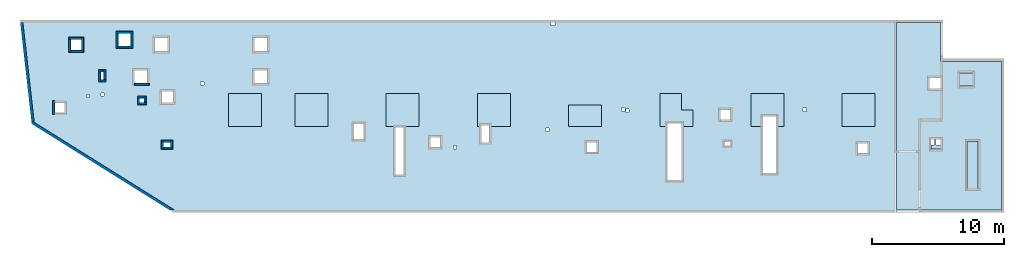
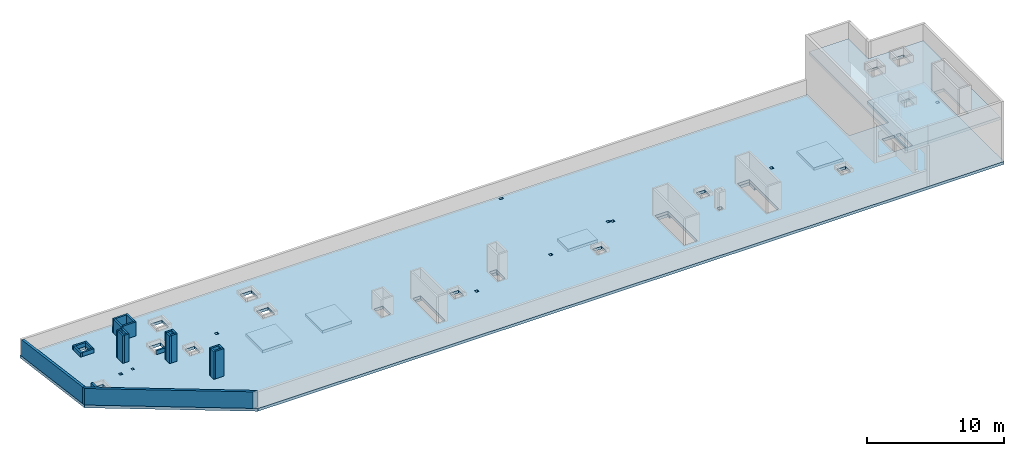
# One storey, part 1 of 3: 24 walls, 10 slabs.
"""IFC4 building model written with IfcOpenShell, lengths in millimetres."""

from ifc_helpers import new_model, entity, si_unit, converted_unit, derived_unit, direction, frame, origin, place, context, subcontext, project, spatial, indexed_curve, outline, extrude, material, type_object, element, save


model = new_model("IFC4")

# Units and contexts
model_context = context("Model", 3, precision=0.01, world=origin(), true_north=direction((6.12303176911189e-17, 1.0)))
plan_context = context("Plan", 3, precision=0.01, world=origin(), true_north=direction((6.12303176911189e-17, 1.0)))
body_context = subcontext(model_context, "Body", "Model", "MODEL_VIEW")
ifc_project = project(units=[si_unit("LENGTHUNIT", "METRE", prefix="MILLI"), si_unit("AREAUNIT", "SQUARE_METRE"), si_unit("VOLUMEUNIT", "CUBIC_METRE"), converted_unit("PLANEANGLEUNIT", "DEGREE", entity("IfcRatioMeasure", 0.0174532925199433), si_unit("PLANEANGLEUNIT", "RADIAN"), dimensions=[0, 0, 0, 0, 0, 0, 0]), si_unit("MASSUNIT", "GRAM", prefix="KILO"), derived_unit("MASSDENSITYUNIT", [(si_unit("MASSUNIT", "GRAM", prefix="KILO"), 1), (si_unit("LENGTHUNIT", "METRE"), -3)]), derived_unit("MOMENTOFINERTIAUNIT", [(si_unit("LENGTHUNIT", "METRE"), 4)]), si_unit("TIMEUNIT", "SECOND"), si_unit("FREQUENCYUNIT", "HERTZ"), si_unit("THERMODYNAMICTEMPERATUREUNIT", "DEGREE_CELSIUS"), derived_unit("THERMALTRANSMITTANCEUNIT", [(si_unit("MASSUNIT", "GRAM", prefix="KILO"), 1), (si_unit("THERMODYNAMICTEMPERATUREUNIT", "KELVIN"), -1), (si_unit("TIMEUNIT", "SECOND"), -3)]), derived_unit("VOLUMETRICFLOWRATEUNIT", [(si_unit("LENGTHUNIT", "METRE"), 3), (si_unit("TIMEUNIT", "SECOND"), -1)]), derived_unit("MASSFLOWRATEUNIT", [(si_unit("MASSUNIT", "GRAM", prefix="KILO"), 1), (si_unit("TIMEUNIT", "SECOND"), -1)]), derived_unit("ROTATIONALFREQUENCYUNIT", [(si_unit("TIMEUNIT", "SECOND"), -1)]), si_unit("ELECTRICCURRENTUNIT", "AMPERE"), si_unit("ELECTRICVOLTAGEUNIT", "VOLT"), si_unit("POWERUNIT", "WATT"), si_unit("FORCEUNIT", "NEWTON", prefix="KILO"), si_unit("ILLUMINANCEUNIT", "LUX"), si_unit("LUMINOUSFLUXUNIT", "LUMEN"), si_unit("LUMINOUSINTENSITYUNIT", "CANDELA"), derived_unit("USERDEFINED", [(si_unit("MASSUNIT", "GRAM", prefix="KILO"), -1), (si_unit("LENGTHUNIT", "METRE"), -2), (si_unit("TIMEUNIT", "SECOND"), 3), (si_unit("LUMINOUSFLUXUNIT", "LUMEN"), 1)]), derived_unit("LINEARVELOCITYUNIT", [(si_unit("LENGTHUNIT", "METRE"), 1), (si_unit("TIMEUNIT", "SECOND"), -1)]), si_unit("PRESSUREUNIT", "PASCAL"), derived_unit("USERDEFINED", [(si_unit("LENGTHUNIT", "METRE"), -2), (si_unit("MASSUNIT", "GRAM", prefix="KILO"), 1), (si_unit("TIMEUNIT", "SECOND"), -2)]), derived_unit("LINEARFORCEUNIT", [(si_unit("MASSUNIT", "GRAM", prefix="KILO"), 1), (si_unit("LENGTHUNIT", "METRE"), 1), (si_unit("TIMEUNIT", "SECOND"), -2), (si_unit("LENGTHUNIT", "METRE"), -1)]), derived_unit("PLANARFORCEUNIT", [(si_unit("MASSUNIT", "GRAM", prefix="KILO"), 1), (si_unit("LENGTHUNIT", "METRE"), 1), (si_unit("TIMEUNIT", "SECOND"), -2), (si_unit("LENGTHUNIT", "METRE"), -2)])], contexts=[model_context, plan_context])

# Site, building, storey
site_placement = place(None, origin())
site = spatial("IfcSite", under=ifc_project, at=site_placement, CompositionType="ELEMENT")
building_placement = place(site_placement, origin())
building = spatial("IfcBuilding", under=site, at=building_placement, CompositionType="ELEMENT")
storey_placement = place(building_placement, frame((0.0, 0.0, 32250.0)))
storey = spatial("IfcBuildingStorey", under=building, at=storey_placement, CompositionType="ELEMENT", Elevation=32250.0)

# Slabs
ifc_material = material()
slab_type_1 = type_object("IfcSlabType", Name=":ADSK_ 25_250", PredefinedType="FLOOR", material=ifc_material)
placement = place(storey_placement, origin())
element("IfcSlab", 1, at=placement, inside=storey, type_object=slab_type_1, material=ifc_material, Name=":ADSK_ 25_250", ObjectType=":ADSK_ 25_250", PredefinedType="FLOOR", context=body_context, shape_type="SweptSolid", body=[
    extrude(outline(indexed_curve([(-28210.243401448, -11264.7051743326), (34622.2927188456, -11264.7051743326), (34622.2927188456, 375.294825667434), (29822.2935367167, 375.294825667426), (29822.2935367167, -2764.70517433255), (26482.2935367167, -2764.70517433256), (26482.2935367167, 3305.29546503463), (-39839.7064632833, 3305.29546503461), (-38947.8468191642, -4555.23683038923), (-28210.243401448, -11264.7051743326)], self_intersect=False), holes=[indexed_curve([(-36462.7064632833, -2944.70517433183), (-36462.7064632833, -3694.70517433183), (-37212.7064632833, -3694.70517433183), (-37212.7064632833, -2944.70517433183), (-36462.7064632833, -2944.70517433183)], self_intersect=False), indexed_curve([(-35152.7064632833, 1855.29482566817), (-35152.7064632833, 1005.29482566817), (-36002.7064632834, 1005.29482566817), (-36002.7064632834, 1855.29482566817), (-35152.7064632833, 1855.29482566817)], self_intersect=False), indexed_curve([(-33497.7064632833, -2234.70517433184), (-33497.7064632833, -2434.70517433184), (-33697.7064632833, -2434.70517433184), (-33697.7064632833, -2234.70517433184), (-33497.7064632833, -2234.70517433184)], self_intersect=False), indexed_curve([(-34567.7064632833, -2324.70517433183), (-34567.7064632833, -2574.70517433183), (-34817.7064632833, -2574.70517433183), (-34817.7064632833, -2324.70517433183), (-34567.7064632833, -2324.70517433183)], self_intersect=False), indexed_curve([(-25922.7064632833, -1369.70517433186), (-25922.7064632833, -1619.70517433186), (-26172.7064632833, -1619.70517433186), (-26172.7064632833, -1369.70517433186), (-25922.7064632833, -1369.70517433186)], self_intersect=False), indexed_curve([(-28247.7064632833, -2094.70517433186), (-28247.7064632833, -2944.70517433186), (-29097.7064632833, -2944.70517433186), (-29097.7064632833, -2094.70517433186), (-28247.7064632833, -2094.70517433186)], self_intersect=False), indexed_curve([(-30447.7064632833, -2604.70517433184), (-30447.7064632833, -2954.70517433184), (-30797.7064632833, -2954.70517433184), (-30797.7064632833, -2604.70517433184), (-30447.7064632833, -2604.70517433184)], self_intersect=False), indexed_curve([(-30197.7064632833, -494.705174331843), (-30197.7064632833, -1494.70517433184), (-31197.7064632833, -1494.70517433185), (-31197.7064632833, -494.705174331847), (-30197.7064632833, -494.705174331843)], self_intersect=False), indexed_curve([(-28647.7064632833, 1955.29546503462), (-28647.7064632833, 955.295465034616), (-29647.7064632833, 955.295465034613), (-29647.7064632833, 1955.29546503462), (-28647.7064632833, 1955.29546503462)], self_intersect=False), indexed_curve([(-31447.7064632833, 2285.29546503462), (-31447.7064632833, 1325.29546503462), (-32407.7064632833, 1325.29546503462), (-32407.7064632833, 2285.29546503461), (-31447.7064632833, 2285.29546503462)], self_intersect=False), indexed_curve([(-33497.7064632833, -624.705174331836), (-33497.7064632833, -1224.70517433184), (-33747.7064632833, -1224.70517433184), (-33747.7064632833, -624.705174331837), (-33497.7064632833, -624.705174331836)], self_intersect=False), indexed_curve([(-28447.7064632833, -5959.70517433185), (-28447.7064632833, -6309.70517433185), (-28997.7064632833, -6309.70517433185), (-28997.7064632833, -5959.70517433185), (-28447.7064632833, -5959.70517433185)], self_intersect=False), indexed_curve([(-21127.7064632833, -494.704534965379), (-21127.7064632833, -1494.70453496538), (-22127.7064632833, -1494.70453496538), (-22127.7064632833, -494.704534965383), (-21127.7064632833, -494.704534965379)], self_intersect=False), indexed_curve([(-21127.7064632833, 1955.29546503462), (-21127.7064632833, 955.29546503462), (-22127.7064632833, 955.295465034621), (-22127.7064632833, 1955.29546503462), (-21127.7064632833, 1955.29546503462)], self_intersect=False), indexed_curve([(-13822.7064632833, -4554.7051743319), (-13822.7064632833, -5704.7051743319), (-14572.7064632833, -5704.7051743319), (-14572.7064632833, -4554.7051743319), (-13822.7064632833, -4554.7051743319)], self_intersect=False), indexed_curve([(-10782.7064632833, -4794.70517433239), (-10782.7064632833, -8394.7051743324), (-11432.7064632833, -8394.7051743324), (-11432.7064632833, -4794.7051743324), (-10782.7064632833, -4794.70517433239)], self_intersect=False), indexed_curve([(-8037.70646328332, -5559.70517433193), (-8037.70646328333, -6309.70517433194), (-8787.70646328334, -6309.70517433194), (-8787.70646328332, -5559.70517433194), (-8037.70646328332, -5559.70517433193)], self_intersect=False), indexed_curve([(-6797.70646328332, -6189.70517433193), (-6797.70646328332, -6439.70517433193), (-7047.70646328332, -6439.70517433192), (-7047.70646328333, -6189.70517433192), (-6797.70646328332, -6189.70517433193)], self_intersect=False), indexed_curve([(-4327.70646328331, -4664.70517433239), (-4327.7064632833, -5964.70517433239), (-4927.7064632833, -5964.7051743324), (-4927.70646328331, -4664.70517433239), (-4327.70646328331, -4664.70517433239)], self_intersect=False), indexed_curve([(197.293536716675, -4869.70517433194), (197.293536716676, -5119.70517433194), (-52.7064632833368, -5119.70517433194), (-52.706463283329, -4869.70517433194), (197.293536716675, -4869.70517433194)], self_intersect=False), indexed_curve([(652.293536716691, 3105.29546503454), (652.293536716692, 2905.29546503454), (352.293536716691, 2905.29546503454), (352.293536716682, 3105.29546503453), (652.293536716691, 3105.29546503454)], self_intersect=False), indexed_curve([(10222.2935367167, -4504.70517433248), (10222.2935367167, -8804.70517433249), (9122.29353671668, -8804.7051743325), (9122.29353671668, -4504.70517433249), (10222.2935367167, -4504.70517433248)], self_intersect=False), indexed_curve([(5937.29353671669, -3329.70517433197), (5937.29353671669, -3579.70517433197), (5687.29353671668, -3579.70517433197), (5687.29353671669, -3329.70517433197), (5937.29353671669, -3329.70517433197)], self_intersect=False), indexed_curve([(6257.2935367167, -3439.70517433198), (6257.29353671668, -3689.70517433198), (6007.29353671668, -3689.70517433198), (6007.29353671669, -3439.70517433198), (6257.2935367167, -3439.70517433198)], self_intersect=False), indexed_curve([(3812.2935367167, -5934.70517433198), (3812.2935367167, -6684.70517433198), (3062.29353671669, -6684.70517433198), (3062.29353671669, -5934.70517433198), (3812.2935367167, -5934.70517433198)], self_intersect=False), indexed_curve([(13912.2935367167, -3494.705174332), (13912.2935367167, -4244.705174332), (13162.2935367167, -4244.705174332), (13162.2935367167, -3494.705174332), (13912.2935367167, -3494.705174332)], self_intersect=False), indexed_curve([(13902.2935367167, -5919.70517433199), (13902.2935367167, -6219.705174332), (13502.2935367167, -6219.705174332), (13502.2935367167, -5919.70517433199), (13902.2935367167, -5919.70517433199)], self_intersect=False), indexed_curve([(17372.2935367167, -3984.70517433251), (17372.2935367167, -8284.70517433251), (16372.2935367167, -8284.70517433252), (16372.2935367167, -3984.70517433252), (17372.2935367167, -3984.70517433251)], self_intersect=False), indexed_curve([(19662.2935367167, -3369.70517433203), (19662.2935367167, -3619.70517433203), (19412.2935367167, -3619.70517433203), (19412.2935367167, -3369.70517433202), (19662.2935367167, -3369.70517433203)], self_intersect=False), indexed_curve([(24297.2935367167, -6034.70517433203), (24297.2935367167, -6784.70517433204), (23547.2935367167, -6784.70517433205), (23547.2935367167, -6034.70517433203), (24297.2935367167, -6034.70517433203)], self_intersect=False), indexed_curve([(34322.2927188456, -2204.70517433205), (34322.2927188456, -2454.70517433206), (34072.2927188456, -2454.70517433207), (34072.2927188456, -2204.70517433205), (34322.2927188456, -2204.70517433205)], self_intersect=False), indexed_curve([(29372.2935367167, -4364.70517433255), (29372.2935367168, -6169.70517433255), (28332.2935367167, -6169.70517433255), (28332.2935367167, -4364.70517433256), (29372.2935367167, -4364.70517433255)], self_intersect=False), indexed_curve([(29872.2935367167, -4364.70517433255), (29872.2935367167, -6169.70517433255), (29492.2935367167, -6169.70517433255), (29492.2935367167, -4364.70517433255), (29822.2935367167, -4364.70517433255), (29872.2935367167, -4364.70517433255)], self_intersect=False)]), frame((38947.71, 17194.7, -250.0)), (0.0, 0.0, 1.0), 249.999999999999),
])
slab_type_2 = type_object("IfcSlabType", Name=":ADSK_ 25_250", PredefinedType="FLOOR", material=ifc_material)
element("IfcSlab", 2, at=placement, inside=storey, type_object=slab_type_2, material=ifc_material, Name=":ADSK_ 25_250", ObjectType=":ADSK_ 25_250", PredefinedType="FLOOR", context=body_context, shape_type="SweptSolid", body=[
    extrude(outline(indexed_curve([(-1250.0, -1250.0), (1250.0, -1250.0), (1250.0, 1250.0), (-1250.0, 1250.0), (-1250.0, -1250.0)], self_intersect=False)), frame((21170.0, 13700.0, -250.0), z_axis=(0.0, 0.0, -1.0), x_axis=(0.0, 1.0, 0.0)), (0.0, 0.0, 1.0), 249.999999999999),
])
slab_type_3 = type_object("IfcSlabType", Name=":ADSK_ 25_250", PredefinedType="FLOOR", material=ifc_material)
element("IfcSlab", 3, at=placement, inside=storey, type_object=slab_type_3, material=ifc_material, Name=":ADSK_ 25_250", ObjectType=":ADSK_ 25_250", PredefinedType="FLOOR", context=body_context, shape_type="SweptSolid", body=[
    extrude(outline(indexed_curve([(-1250.0, -1250.0), (1250.0, -1250.0), (1250.0, 1250.0), (-1250.0, 1250.0), (-1250.0, -1250.0)], self_intersect=False)), frame((16150.0, 13700.0, -250.0), z_axis=(0.0, 0.0, -1.0), x_axis=(0.0, 1.0, 0.0)), (0.0, 0.0, 1.0), 249.999999999999),
])
slab_type_4 = type_object("IfcSlabType", Name=":ADSK_ 25_250", PredefinedType="FLOOR", material=ifc_material)
element("IfcSlab", 4, at=placement, inside=storey, type_object=slab_type_4, material=ifc_material, Name=":ADSK_ 25_250", ObjectType=":ADSK_ 25_250", PredefinedType="FLOOR", context=body_context, shape_type="SweptSolid", body=[
    extrude(outline(indexed_curve([(-1250.0, -1250.0), (1250.0, -1250.0), (1250.0, 1250.0), (-1250.0, 1250.0), (-1250.0, -1250.0)], self_intersect=False)), frame((28070.0, 13700.0, -250.0), z_axis=(0.0, 0.0, -1.0), x_axis=(0.0, 1.0, 0.0)), (0.0, 0.0, 1.0), 249.999999999999),
])
slab_type_5 = type_object("IfcSlabType", Name=":ADSK_ 25_250", PredefinedType="FLOOR", material=ifc_material)
element("IfcSlab", 5, at=placement, inside=storey, type_object=slab_type_5, material=ifc_material, Name=":ADSK_ 25_250", ObjectType=":ADSK_ 25_250", PredefinedType="FLOOR", context=body_context, shape_type="SweptSolid", body=[
    extrude(outline(indexed_curve([(-645.000000000002, -925.0), (1855.0, -925.0), (1855.0, 1575.0), (-645.000000000002, 1575.0), (-645.000000000001, -24.9999999999964), (-564.999999999999, -24.9999999999967), (-565.000000000001, -624.999999999999), (-645.000000000001, -624.999999999999), (-645.000000000002, -925.0)], self_intersect=False)), frame((34645.0, 13095.0, -250.0), z_axis=(0.0, 0.0, -1.0), x_axis=(0.0, 1.0, 0.0)), (0.0, 0.0, 1.0), 249.999999999999),
])
slab_type_6 = type_object("IfcSlabType", Name=":ADSK_ 25_250", PredefinedType="FLOOR", material=ifc_material)
element("IfcSlab", 6, at=placement, inside=storey, type_object=slab_type_6, material=ifc_material, Name=":ADSK_ 25_250", ObjectType=":ADSK_ 25_250", PredefinedType="FLOOR", context=body_context, shape_type="SweptSolid", body=[
    extrude(outline(indexed_curve([(-799.999999999968, -1250.0), (799.999999999963, -1250.0), (799.999999999968, 1250.00000000001), (-799.999999999963, 1250.00000000001), (-799.999999999968, -1250.0)], self_intersect=False)), frame((41870.0, 13250.0, -250.0), z_axis=(0.0, 0.0, -1.0), x_axis=(0.0, 1.0, 0.0)), (0.0, 0.0, 1.0), 249.999999999999),
])
slab_type_7 = type_object("IfcSlabType", Name=":ADSK_ 25_250", PredefinedType="FLOOR", material=ifc_material)
element("IfcSlab", 7, at=placement, inside=storey, type_object=slab_type_7, material=ifc_material, Name=":ADSK_ 25_250", ObjectType=":ADSK_ 25_250", PredefinedType="FLOOR", context=body_context, shape_type="SweptSolid", body=[
    extrude(outline(indexed_curve([(-797.999999999962, -1270.00000000001), (1702.00000000004, -1270.00000000001), (1702.00000000004, 379.999999999997), (451.999999999941, 380.000000000006), (451.999999999945, 1229.99999999999), (-797.999999999953, 1229.99999999999), (-797.999999999957, 379.999999999997), (-558.000000000055, 379.999999999995), (-558.000000000062, -719.999999999997), (-797.99999999996, -719.999999999995), (-797.999999999962, -1270.00000000001)], self_intersect=False)), frame((48790.0, 13248.0, -250.0), z_axis=(0.0, 0.0, -1.0), x_axis=(0.0, 1.0, 0.0)), (0.0, 0.0, 1.0), 249.999999999999),
])
slab_type_8 = type_object("IfcSlabType", Name=":ADSK_ 25_250", PredefinedType="FLOOR", material=ifc_material)
element("IfcSlab", 8, at=placement, inside=storey, type_object=slab_type_8, material=ifc_material, Name=":ADSK_ 25_250", ObjectType=":ADSK_ 25_250", PredefinedType="FLOOR", context=body_context, shape_type="SweptSolid", body=[
    extrude(outline(indexed_curve([(-814.999999999971, -1325.0), (1685.00000000003, -1325.0), (1685.00000000004, 1175.0), (-814.999999999962, 1175.00000000001), (-814.999999999965, 575.000000000005), (-55.0000000000918, 575.0), (-55.0000000000987, -424.999999999998), (-814.999999999967, -424.999999999993), (-814.999999999971, -1325.0)], self_intersect=False)), frame((55745.0, 13265.0, -250.0), z_axis=(0.0, 0.0, -1.0), x_axis=(0.0, 1.0, 0.0)), (0.0, 0.0, 1.0), 249.999999999999),
])
slab_type_9 = type_object("IfcSlabType", Name=":ADSK_ 25_250", PredefinedType="FLOOR", material=ifc_material)
element("IfcSlab", 9, at=placement, inside=storey, type_object=slab_type_9, material=ifc_material, Name=":ADSK_ 25_250", ObjectType=":ADSK_ 25_250", PredefinedType="FLOOR", context=body_context, shape_type="SweptSolid", body=[
    extrude(outline(indexed_curve([(-1250.0, -1250.00000000001), (1250.0, -1250.00000000001), (1250.0, 1250.0), (-1250.0, 1250.0), (-1250.0, -1250.00000000001)], self_intersect=False)), frame((62570.0, 13700.0, -250.0), z_axis=(0.0, 0.0, -1.0), x_axis=(0.0, 1.0, 0.0)), (0.0, 0.0, 1.0), 249.999999999999),
])
slab_type_10 = type_object("IfcSlabType", Name=":ADSK_ 25_250", PredefinedType="FLOOR", material=ifc_material)
element("IfcSlab", 10, at=placement, inside=storey, type_object=slab_type_10, material=ifc_material, Name=":ADSK_ 25_250", ObjectType=":ADSK_ 25_250", PredefinedType="FLOOR", context=body_context, shape_type="SweptSolid", body=[
    extrude(outline(indexed_curve([(-4717.14227294921, 3352.14285714262), (-4717.14227294921, -7887.85714285738), (3222.85690917966, -7887.85714285738), (3222.85690917966, -3492.85714285684), (3222.85690917966, 6282.14285714318), (-117.143090820333, 6282.14285714317), (-117.143090820325, 3352.14285714262), (-4717.14227294921, 3352.14285714262)], self_intersect=False), holes=[indexed_curve([(-117.143090820307, 2122.14285714314), (732.856909179725, 2122.14285714314), (732.856909179725, 1272.14285714314), (-117.143090820307, 1272.14285714314), (-117.143090820307, 2122.14285714314)], self_intersect=False), indexed_curve([(-2567.14309082028, 2482.14285714312), (-1567.14309082028, 2482.14285714312), (-1567.14309082028, 1482.14285714312), (-2567.14309082028, 1482.14285714312), (-2567.14309082028, 2482.14285714312)], self_intersect=False), indexed_curve([(-142.143090820267, -2532.85714285686), (607.856909179736, -2532.85714285686), (607.856909179736, -3282.85714285686), (-142.143090820267, -3282.85714285686), (-142.143090820267, -2532.85714285686)], self_intersect=False), indexed_curve([(-2967.1422729492, -2702.85714285687), (-2117.14227294921, -2702.85714285687), (-2117.14227294921, -6302.85714285688), (-2967.1422729492, -6302.85714285688), (-2967.1422729492, -2702.85714285687)], self_intersect=False)]), frame((68652.86, 14017.86, 3650.0), z_axis=(0.0, 0.0, -1.0), x_axis=(-1.0, 0.0, 0.0)), (0.0, 0.0, -1.0), 249.999999999999),
])

# Walls
wall_type_1 = type_object("IfcWallType", Name=":ADSK_ 25_200", PredefinedType="STANDARD")
wall_1_placement = place(storey_placement, frame((10741.82, 6045.19, 0.0), z_axis=(0.0, 0.0, 1.0), x_axis=(-0.848052743777573, 0.529911826412027, 0.0)))
element("IfcWall", 11, at=wall_1_placement, inside=storey, type_object=wall_type_1, material=ifc_material, Name=":ADSK_ 25_200", ObjectType=":ADSK_ 25_200", PredefinedType="NOTDEFINED", context=body_context, shape_type="SweptSolid", body=[
    extrude(outline(indexed_curve([(12763.0637399361, -100.000000000002), (12604.1325363923, 99.9999999999978), (320.073152365613, 100.000000000001), (-9.89808235374312e-13, -100.000000000001), (12507.6050789753, -100.000000000002), (12763.0637399361, -100.000000000002)], self_intersect=False)), origin(), (0.0, 0.0, 1.0), 1470.0),
])
wall_2_placement = place(storey_placement, frame((88.34, 12746.65, 0.0), z_axis=(0.0, 0.0, 1.0), x_axis=(-0.11273713659355, 0.993624847733131, 0.0)))
element("IfcWall", 12, at=wall_2_placement, inside=storey, type_object=wall_type_1, material=ifc_material, Name=":ADSK_ 25_200", ObjectType=":ADSK_ 25_200", PredefinedType="NOTDEFINED", context=body_context, shape_type="SweptSolid", body=[
    extrude(outline(indexed_curve([(7590.46314626056, -100.0), (7613.15523912654, 100.0), (158.931203543748, 100.0), (9.11554165483608e-13, -100.0), (7590.46314626056, -100.0)], self_intersect=False)), origin(), (0.0, 0.0, 1.0), 1470.0),
])
wall_type_2 = type_object("IfcWallType", Name=":ADSK_ 25_150", PredefinedType="STANDARD")
wall_3_placement = place(storey_placement, frame((1660.0, 13350.0, 0.0), z_axis=(0.0, 0.0, 1.0), x_axis=(0.0, 1.0, 0.0)))
element("IfcWall", 13, at=wall_3_placement, inside=storey, type_object=wall_type_2, material=ifc_material, Name=":ADSK_ 25_150", ObjectType=":ADSK_ 25_150", PredefinedType="NOTDEFINED", context=body_context, shape_type="SweptSolid", body=[
    extrude(outline(indexed_curve([(1050.0, 74.9999999999999), (-1.08286712929839e-13, 75.0), (1.08286712929839e-13, -75.0), (1050.0, -75.0000000000001), (1050.0, 74.9999999999999)], self_intersect=False)), origin(), (0.0, 0.0, 1.0), 349.999999999998),
])
wall_4_placement = place(storey_placement, frame((2795.0, 19125.0, 0.0)))
element("IfcWall", 14, at=wall_4_placement, inside=storey, type_object=wall_type_2, material=ifc_material, Name=":ADSK_ 25_150", ObjectType=":ADSK_ 25_150", PredefinedType="NOTDEFINED", context=body_context, shape_type="SweptSolid", body=[
    extrude(outline(indexed_curve([(1000.0, 75.0000000000003), (0.0, 75.0000000000003), (0.0, -75.0000000000003), (1000.0, -75.0000000000003), (1000.0, 75.0000000000003)], self_intersect=False)), origin(), (0.0, 0.0, 1.0), 349.999999999998),
])
wall_5_placement = place(storey_placement, frame((2870.0, 18050.0, 0.0), z_axis=(0.0, 0.0, 1.0), x_axis=(0.0, 1.0, 0.0)))
element("IfcWall", 15, at=wall_5_placement, inside=storey, type_object=wall_type_2, material=ifc_material, Name=":ADSK_ 25_150", ObjectType=":ADSK_ 25_150", PredefinedType="NOTDEFINED", context=body_context, shape_type="SweptSolid", body=[
    extrude(outline(indexed_curve([(999.999999999998, 75.0000000000003), (0.0, 75.0000000000003), (0.0, -75.0000000000003), (999.999999999998, -75.0000000000003), (999.999999999998, 75.0000000000003)], self_intersect=False)), origin(), (0.0, 0.0, 1.0), 349.999999999998),
])
wall_6_placement = place(storey_placement, frame((3945.0, 18125.0, 0.0), z_axis=(0.0, 0.0, 1.0), x_axis=(-1.0, 0.0, 0.0)))
element("IfcWall", 16, at=wall_6_placement, inside=storey, type_object=wall_type_2, material=ifc_material, Name=":ADSK_ 25_150", ObjectType=":ADSK_ 25_150", PredefinedType="NOTDEFINED", context=body_context, shape_type="SweptSolid", body=[
    extrude(outline(indexed_curve([(1000.0, 75.0000000000003), (0.0, 75.0000000000003), (0.0, -75.0000000000003), (1000.0, -75.0000000000003), (1000.0, 75.0000000000003)], self_intersect=False)), origin(), (0.0, 0.0, 1.0), 349.999999999998),
])
wall_7_placement = place(storey_placement, frame((3870.0, 19200.0, 0.0), z_axis=(0.0, 0.0, 1.0), x_axis=(0.0, -1.0, 0.0)))
element("IfcWall", 17, at=wall_7_placement, inside=storey, type_object=wall_type_2, material=ifc_material, Name=":ADSK_ 25_150", ObjectType=":ADSK_ 25_150", PredefinedType="NOTDEFINED", context=body_context, shape_type="SweptSolid", body=[
    extrude(outline(indexed_curve([(999.999999999998, 75.0000000000003), (0.0, 75.0000000000003), (0.0, -75.0000000000003), (999.999999999998, -75.0000000000003), (999.999999999998, 75.0000000000003)], self_intersect=False)), origin(), (0.0, 0.0, 1.0), 349.999999999998),
])
wall_8_placement = place(storey_placement, frame((8900.0, 15625.0, 0.0), z_axis=(0.0, 0.0, 1.0), x_axis=(-1.0, 0.0, 0.0)))
element("IfcWall", 18, at=wall_8_placement, inside=storey, type_object=wall_type_2, material=ifc_material, Name=":ADSK_ 25_150", ObjectType=":ADSK_ 25_150", PredefinedType="NOTDEFINED", context=body_context, shape_type="SweptSolid", body=[
    extrude(outline(indexed_curve([(1150.0, 75.0000000000003), (0.0, 75.0000000000003), (0.0, -75.0000000000003), (1150.0, -75.0000000000003), (1150.0, 75.0000000000003)], self_intersect=False)), origin(), (0.0, 0.0, 1.0), 349.999999999998),
])
wall_9_placement = place(storey_placement, frame((8000.0, 14665.0, 0.0)))
element("IfcWall", 19, at=wall_9_placement, inside=storey, type_object=wall_type_2, material=ifc_material, Name=":ADSK_ 25_150", ObjectType=":ADSK_ 25_150", PredefinedType="NOTDEFINED", context=body_context, shape_type="SweptSolid", body=[
    extrude(outline(indexed_curve([(499.999999999999, 75.0000000000003), (0.0, 75.0000000000003), (0.0, -75.0000000000003), (499.999999999999, -75.0000000000003), (499.999999999999, 75.0000000000003)], self_intersect=False)), origin(), (0.0, 0.0, 1.0), 2450.0),
])
for number, where, z_axis, x_axis, name in (
    (20, (8075.0, 14090.0, 0.0), (0.0, 0.0, 1.0), (0.0, 1.0, 0.0), ":ADSK_ 25_150"),
    (21, (8650.0, 14165.0, 0.0), (0.0, 0.0, 1.0), (-1.0, 0.0, 0.0), ":ADSK_ 25_150"),
    (22, (8575.0, 14740.0, 0.0), (0.0, 0.0, 1.0), (0.0, -1.0, 0.0), ":ADSK_ 25_150"),
):
    element("IfcWall", number, at=place(storey_placement, frame(where, z_axis=z_axis, x_axis=x_axis)), inside=storey, type_object=wall_type_2, material=ifc_material, Name=name, ObjectType=":ADSK_ 25_150", PredefinedType="NOTDEFINED", context=body_context, shape_type="SweptSolid", body=[
        extrude(outline(indexed_curve([(499.999999999999, 75.0000000000003), (0.0, 75.0000000000003), (0.0, -75.0000000000003), (499.999999999999, -75.0000000000003), (499.999999999999, 75.0000000000003)], self_intersect=False)), origin(), (0.0, 0.0, 1.0), 2450.0),
    ])
wall_10_placement = place(storey_placement, frame((5050.0, 16645.0, 0.0)))
element("IfcWall", 23, at=wall_10_placement, inside=storey, type_object=wall_type_2, material=ifc_material, Name=":ADSK_ 25_150", ObjectType=":ADSK_ 25_150", PredefinedType="NOTDEFINED", context=body_context, shape_type="SweptSolid", body=[
    extrude(outline(indexed_curve([(399.999999999999, 75.0000000000003), (0.0, 75.0000000000003), (0.0, -75.0000000000003), (399.999999999999, -75.0000000000003), (399.999999999999, 75.0000000000003)], self_intersect=False)), origin(), (0.0, 0.0, 1.0), 2450.0),
])
wall_11_placement = place(storey_placement, frame((5125.0, 15820.0, 0.0), z_axis=(0.0, 0.0, 1.0), x_axis=(0.0, 1.0, 0.0)))
element("IfcWall", 24, at=wall_11_placement, inside=storey, type_object=wall_type_2, material=ifc_material, Name=":ADSK_ 25_150", ObjectType=":ADSK_ 25_150", PredefinedType="NOTDEFINED", context=body_context, shape_type="SweptSolid", body=[
    extrude(outline(indexed_curve([(750.000000000003, 75.0000000000003), (0.0, 75.0000000000003), (0.0, -75.0000000000003), (750.000000000003, -75.0000000000003), (750.000000000003, 75.0000000000003)], self_intersect=False)), origin(), (0.0, 0.0, 1.0), 2450.0),
])
wall_12_placement = place(storey_placement, frame((5600.0, 15895.0, 0.0), z_axis=(0.0, 0.0, 1.0), x_axis=(-1.0, 0.0, 0.0)))
element("IfcWall", 25, at=wall_12_placement, inside=storey, type_object=wall_type_2, material=ifc_material, Name=":ADSK_ 25_150", ObjectType=":ADSK_ 25_150", PredefinedType="NOTDEFINED", context=body_context, shape_type="SweptSolid", body=[
    extrude(outline(indexed_curve([(400.000000000003, 75.0000000000003), (0.0, 75.0000000000003), (0.0, -75.0000000000003), (400.000000000003, -75.0000000000003), (400.000000000003, 75.0000000000003)], self_intersect=False)), origin(), (0.0, 0.0, 1.0), 2450.0),
])
wall_13_placement = place(storey_placement, frame((5525.0, 16720.0, 0.0), z_axis=(0.0, 0.0, 1.0), x_axis=(0.0, -1.0, 0.0)))
element("IfcWall", 26, at=wall_13_placement, inside=storey, type_object=wall_type_2, material=ifc_material, Name=":ADSK_ 25_150", ObjectType=":ADSK_ 25_150", PredefinedType="NOTDEFINED", context=body_context, shape_type="SweptSolid", body=[
    extrude(outline(indexed_curve([(750.000000000003, 74.9999999999997), (2.75612141970114e-13, 75.0000000000003), (-2.75612141970114e-13, -75.0000000000003), (750.000000000003, -75.0000000000009), (750.000000000003, 74.9999999999997)], self_intersect=False)), origin(), (0.0, 0.0, 1.0), 2450.0),
])
wall_14_placement = place(storey_placement, frame((6390.0, 19555.0, 0.0)))
element("IfcWall", 27, at=wall_14_placement, inside=storey, type_object=wall_type_2, material=ifc_material, Name=":ADSK_ 25_150", ObjectType=":ADSK_ 25_150", PredefinedType="NOTDEFINED", context=body_context, shape_type="SweptSolid", body=[
    extrude(outline(indexed_curve([(1110.0, 75.0000000000003), (0.0, 75.0000000000003), (0.0, -75.0000000000003), (1110.0, -75.0000000000003), (1110.0, 75.0000000000003)], self_intersect=False)), origin(), (0.0, 0.0, 1.0), 1250.0),
])
for number, where, z_axis, x_axis, name in (
    (28, (6465.0, 18370.0, 0.0), (0.0, 0.0, 1.0), (0.0, 1.0, 0.0), ":ADSK_ 25_150"),
    (29, (7650.0, 18445.0, 0.0), (0.0, 0.0, 1.0), (-1.0, 0.0, 0.0), ":ADSK_ 25_150"),
):
    element("IfcWall", number, at=place(storey_placement, frame(where, z_axis=z_axis, x_axis=x_axis)), inside=storey, type_object=wall_type_2, material=ifc_material, Name=name, ObjectType=":ADSK_ 25_150", PredefinedType="NOTDEFINED", context=body_context, shape_type="SweptSolid", body=[
        extrude(outline(indexed_curve([(1110.0, 75.0000000000003), (0.0, 75.0000000000003), (0.0, -75.0000000000003), (1110.0, -75.0000000000003), (1110.0, 75.0000000000003)], self_intersect=False)), origin(), (0.0, 0.0, 1.0), 1250.0),
    ])
wall_15_placement = place(storey_placement, frame((7575.0, 19630.0, 0.0), z_axis=(0.0, 0.0, 1.0), x_axis=(0.0, -1.0, 0.0)))
element("IfcWall", 30, at=wall_15_placement, inside=storey, type_object=wall_type_2, material=ifc_material, Name=":ADSK_ 25_150", ObjectType=":ADSK_ 25_150", PredefinedType="NOTDEFINED", context=body_context, shape_type="SweptSolid", body=[
    extrude(outline(indexed_curve([(1110.0, 75.0000000000003), (7.31666979255673e-14, 75.0000000000003), (-7.31666979255673e-14, -75.0000000000003), (1110.0, -75.0000000000003), (1110.0, 75.0000000000003)], self_intersect=False)), origin(), (0.0, 0.0, 1.0), 1250.0),
])
wall_16_placement = place(storey_placement, frame((9800.0, 11310.0, 0.0)))
element("IfcWall", 31, at=wall_16_placement, inside=storey, type_object=wall_type_2, material=ifc_material, Name=":ADSK_ 25_150", ObjectType=":ADSK_ 25_150", PredefinedType="NOTDEFINED", context=body_context, shape_type="SweptSolid", body=[
    extrude(outline(indexed_curve([(700.000000000001, 75.0000000000003), (0.0, 75.0000000000003), (0.0, -75.0000000000003), (700.000000000001, -75.0000000000003), (700.000000000001, 75.0000000000003)], self_intersect=False)), origin(), (0.0, 0.0, 1.0), 2450.0),
])
wall_17_placement = place(storey_placement, frame((9875.0, 10735.0, 0.0), z_axis=(0.0, 0.0, 1.0), x_axis=(0.0, 1.0, 0.0)))
element("IfcWall", 32, at=wall_17_placement, inside=storey, type_object=wall_type_2, material=ifc_material, Name=":ADSK_ 25_150", ObjectType=":ADSK_ 25_150", PredefinedType="NOTDEFINED", context=body_context, shape_type="SweptSolid", body=[
    extrude(outline(indexed_curve([(500.000000000001, 75.0000000000003), (0.0, 75.0000000000003), (0.0, -75.0000000000003), (500.000000000001, -75.0000000000003), (500.000000000001, 75.0000000000003)], self_intersect=False)), origin(), (0.0, 0.0, 1.0), 2450.0),
])
wall_18_placement = place(storey_placement, frame((10650.0, 10810.0, 0.0), z_axis=(0.0, 0.0, 1.0), x_axis=(-1.0, 0.0, 0.0)))
element("IfcWall", 33, at=wall_18_placement, inside=storey, type_object=wall_type_2, material=ifc_material, Name=":ADSK_ 25_150", ObjectType=":ADSK_ 25_150", PredefinedType="NOTDEFINED", context=body_context, shape_type="SweptSolid", body=[
    extrude(outline(indexed_curve([(700.000000000001, 75.0000000000003), (0.0, 75.0000000000003), (0.0, -75.0000000000003), (700.000000000001, -75.0000000000003), (700.000000000001, 75.0000000000003)], self_intersect=False)), origin(), (0.0, 0.0, 1.0), 2450.0),
])
wall_19_placement = place(storey_placement, frame((10575.0, 11385.0, 0.0), z_axis=(0.0, 0.0, 1.0), x_axis=(0.0, -1.0, 0.0)))
element("IfcWall", 34, at=wall_19_placement, inside=storey, type_object=wall_type_2, material=ifc_material, Name=":ADSK_ 25_150", ObjectType=":ADSK_ 25_150", PredefinedType="NOTDEFINED", context=body_context, shape_type="SweptSolid", body=[
    extrude(outline(indexed_curve([(500.000000000001, 75.0000000000003), (0.0, 75.0000000000003), (0.0, -75.0000000000003), (500.000000000001, -75.0000000000003), (500.000000000001, 75.0000000000003)], self_intersect=False)), origin(), (0.0, 0.0, 1.0), 2450.0),
])

save(model, "model.ifc")
